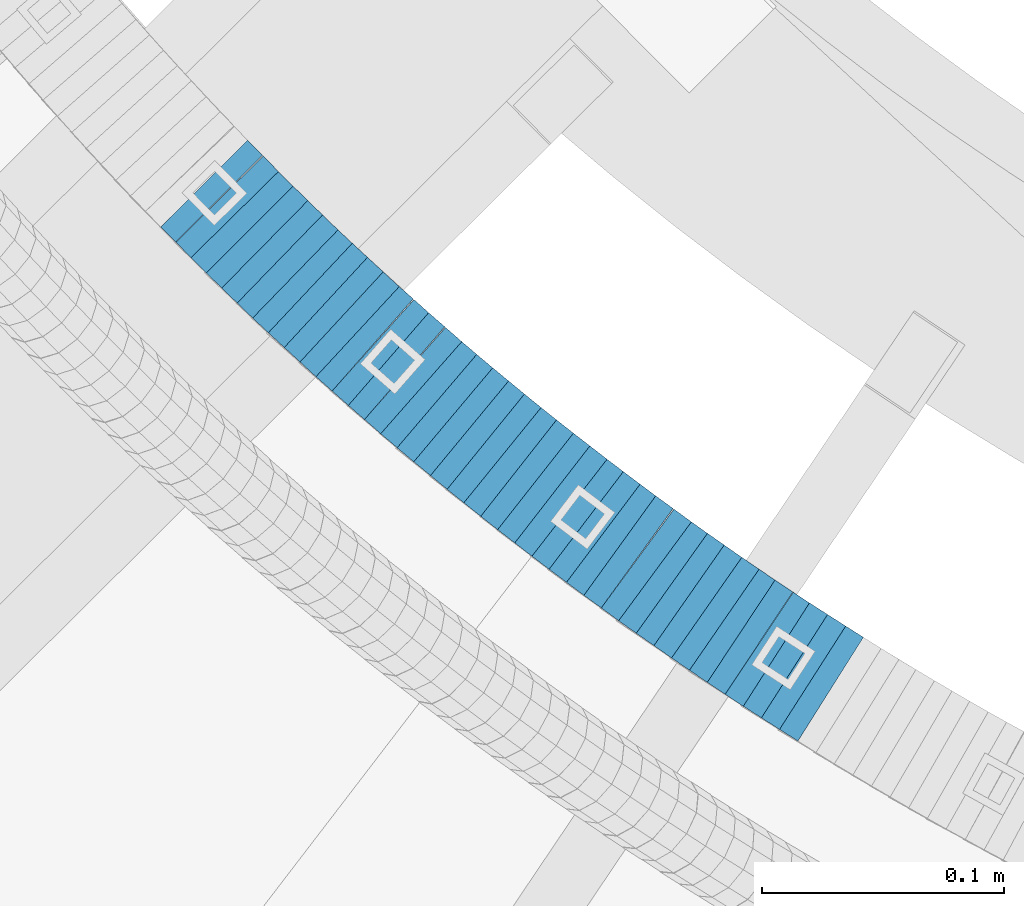
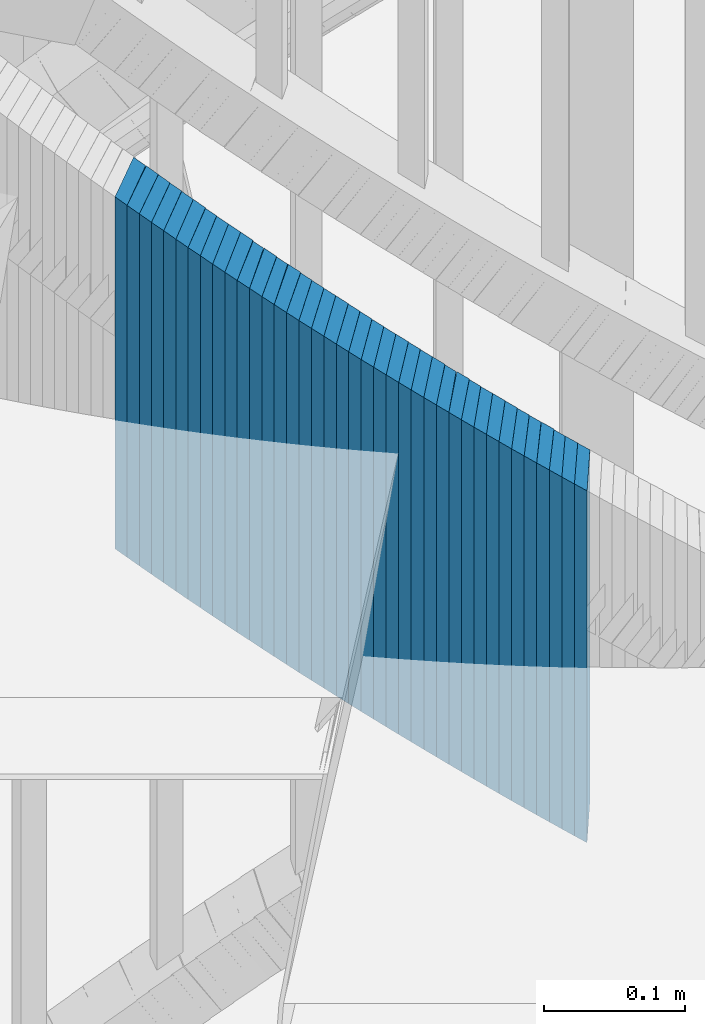
# One storey, part 887 of 975: 38 plates.
"""IFC2X3 building model written with IfcOpenShell, lengths in millimetres."""

from ifc_helpers import new_model, si_unit, frame, origin_with_axes, place, context, subcontext, project, spatial, faceted_brep, material, type_object, element, save


model = new_model("IFC2X3")

# Units and contexts
model_context = context("Model", 3, precision=1e-05, world=origin_with_axes())
body_context = subcontext(model_context, "Body", "Model", "MODEL_VIEW")
ifc_project = project(units=[si_unit("LENGTHUNIT", "METRE", prefix="MILLI"), si_unit("AREAUNIT", "SQUARE_METRE"), si_unit("VOLUMEUNIT", "CUBIC_METRE"), si_unit("MASSUNIT", "GRAM", prefix="KILO"), si_unit("TIMEUNIT", "SECOND"), si_unit("PLANEANGLEUNIT", "RADIAN"), si_unit("SOLIDANGLEUNIT", "STERADIAN"), si_unit("THERMODYNAMICTEMPERATUREUNIT", "DEGREE_CELSIUS"), si_unit("LUMINOUSINTENSITYUNIT", "LUMEN")], contexts=[model_context])

# Site, building, storey
site_placement = place(None, origin_with_axes())
site = spatial("IfcSite", under=ifc_project, at=site_placement, CompositionType="ELEMENT")
building_placement = place(site_placement, origin_with_axes())
building = spatial("IfcBuilding", under=site, at=building_placement, Name="Undefined", CompositionType="ELEMENT")
storey_placement = place(building_placement, origin_with_axes())
storey = spatial("IfcBuildingStorey", under=building, at=storey_placement, Name="Undefined", CompositionType="ELEMENT", Elevation=0.0)

# Plates
ifc_material = material(Name="STEEL/A36")
plate_type = type_object("IfcPlateType", PredefinedType="NOTDEFINED")
plate_1_placement = place(storey_placement, frame((33739.9257432676, 2422.43444188556, 3793.22500005032), z_axis=(-0.707106781186601, 0.707106781186494, 2.36468622460961e-14), x_axis=(0.0, 0.0, 1.0)))
element("IfcPlate", 1, at=plate_1_placement, inside=storey, type_object=plate_type, material=ifc_material, Name="WALL", context=body_context, shape_type="Brep", body=[
    faceted_brep([(0.0, -25.3999999999724, -1.81898940354586e-11), (5.80000019073486, -25.3999999999796, 8.91403388975959), (5.80000019073486, 25.3999999999432, 8.91403388980689), (0.0, 25.3999999999869, 1.45519152283669e-11), (310.600006103515, -25.3999999999796, 8.91403388975959), (310.600006103515, 25.3999999999432, 8.91403388980689), (304.799987792969, -25.3999999999724, -1.81898940354586e-11), (304.799987792969, 25.3999999999869, 1.45519152283669e-11)], [[[0, 1, 2, 3]], [[1, 4, 5, 2]], [[4, 6, 7, 5]], [[6, 0, 3, 7]], [[5, 7, 3, 2]], [[6, 4, 1, 0]]]),
])
plate_2_placement = place(storey_placement, frame((33746.3666034738, 2415.89246817069, 3787.52500005032), z_axis=(-0.701517264855551, 0.712652458853252, 0.0), x_axis=(0.0, 0.0, 1.0)))
element("IfcPlate", 2, at=plate_2_placement, inside=storey, type_object=plate_type, material=ifc_material, Name="WALL", context=body_context, shape_type="Brep", body=[
    faceted_brep([(0.0, -25.3999999999724, -1.81898940354586e-11), (5.69999980926514, -25.3999999999542, 8.98276138300935), (5.69999980926514, 25.3999999999614, 8.98276138309302), (0.0, 25.3999999999869, 1.45519152283669e-11), (310.5, -25.3999999999542, 8.98276138300935), (310.5, 25.3999999999614, 8.98276138309302), (304.799987792969, -25.3999999999724, -1.81898940354586e-11), (304.799987792969, 25.3999999999869, 1.45519152283669e-11)], [[[0, 1, 2, 3]], [[1, 4, 5, 2]], [[4, 6, 7, 5]], [[6, 0, 3, 7]], [[5, 7, 3, 2]], [[6, 4, 1, 0]]]),
])
plate_3_placement = place(storey_placement, frame((33752.5257432694, 2409.73444188556, 3781.82500005032), z_axis=(-0.707106781186601, 0.707106781186494, 2.36468622460961e-14), x_axis=(0.0, 0.0, 1.0)))
element("IfcPlate", 3, at=plate_3_placement, inside=storey, type_object=plate_type, material=ifc_material, Name="WALL", context=body_context, shape_type="Brep", body=[
    faceted_brep([(0.0, -25.3999999999724, -1.81898940354586e-11), (5.69999980926514, -25.4000000000269, 8.91066741947361), (5.69999980926514, 25.4000000000269, 8.91066741941904), (0.0, 25.3999999999869, 1.45519152283669e-11), (310.5, -25.4000000000269, 8.91066741947361), (310.5, 25.4000000000269, 8.91066741941904), (304.799987792969, -25.3999999999724, -1.81898940354586e-11), (304.799987792969, 25.3999999999869, 1.45519152283669e-11)], [[[0, 1, 2, 3]], [[1, 4, 5, 2]], [[4, 6, 7, 5]], [[6, 0, 3, 7]], [[5, 7, 3, 2]], [[6, 4, 1, 0]]]),
])
plate_4_placement = place(storey_placement, frame((33758.7837695498, 2403.57530209825, 3776.12500005032), z_axis=(-0.712652459353194, 0.701517264347674, 0.0), x_axis=(0.0, 0.0, 1.0)))
element("IfcPlate", 4, at=plate_4_placement, inside=storey, type_object=plate_type, material=ifc_material, Name="WALL", context=body_context, shape_type="Brep", body=[
    faceted_brep([(0.0, -25.3999999999724, -1.81898940354586e-11), (5.69999980926514, -25.3999999999542, 8.98276138300935), (5.69999980926514, 25.3999999999614, 8.98276138309302), (0.0, 25.3999999999869, 1.45519152283669e-11), (310.5, -25.3999999999542, 8.98276138300935), (310.5, 25.3999999999614, 8.98276138309302), (304.799987792969, -25.3999999999724, -1.81898940354586e-11), (304.799987792969, 25.3999999999869, 1.45519152283669e-11)], [[[0, 1, 2, 3]], [[1, 4, 5, 2]], [[4, 6, 7, 5]], [[6, 0, 3, 7]], [[5, 7, 3, 2]], [[6, 4, 1, 0]]]),
])
plate_5_placement = place(storey_placement, frame((33765.038429499, 2397.51723130203, 3770.32500005032), z_axis=(-0.718240222804791, 0.695795215810891, 0.0), x_axis=(0.0, 0.0, 1.0)))
element("IfcPlate", 5, at=plate_5_placement, inside=storey, type_object=plate_type, material=ifc_material, Name="WALL", context=body_context, shape_type="Brep", body=[
    faceted_brep([(0.0, -25.3999999999724, -1.81898940354586e-11), (5.80000019073486, -25.3999999999796, 8.91403388975959), (5.80000019073486, 25.3999999999432, 8.91403388980689), (0.0, 25.3999999999869, 1.45519152283669e-11), (310.600006103515, -25.3999999999796, 8.91403388975959), (310.600006103515, 25.3999999999432, 8.91403388980689), (304.799987792969, -25.3999999999724, -1.81898940354586e-11), (304.799987792969, 25.3999999999869, 1.45519152283669e-11)], [[[0, 1, 2, 3]], [[1, 4, 5, 2]], [[4, 6, 7, 5]], [[6, 0, 3, 7]], [[5, 7, 3, 2]], [[6, 4, 1, 0]]]),
])
for number, where, z_axis, x_axis, name in (
    (6, (33771.4384294939, 2391.31723130137, 3764.62500005032), (-0.718240222804791, 0.695795215810891, 0.0), (0.0, 0.0, 1.0), "WALL"),
    (7, (33777.6468117863, 2385.4952862224, 3758.92500005032), (-0.729187266944916, 0.684314203948306, 0.0), (0.0, 0.0, 1.0), "WALL"),
):
    element("IfcPlate", number, at=place(storey_placement, frame(where, z_axis=z_axis, x_axis=x_axis)), inside=storey, type_object=plate_type, material=ifc_material, Name=name, context=body_context, shape_type="Brep", body=[
        faceted_brep([(0.0, -25.3999999999724, -1.81898940354586e-11), (5.69999980926514, -25.4000000000269, 8.91066741947361), (5.69999980926514, 25.4000000000269, 8.91066741941904), (0.0, 25.3999999999869, 1.45519152283669e-11), (310.5, -25.4000000000269, 8.91066741947361), (310.5, 25.4000000000269, 8.91066741941904), (304.799987792969, -25.3999999999724, -1.81898940354586e-11), (304.799987792969, 25.3999999999869, 1.45519152283669e-11)], [[[0, 1, 2, 3]], [[1, 4, 5, 2]], [[4, 6, 7, 5]], [[6, 0, 3, 7]], [[5, 7, 3, 2]], [[6, 4, 1, 0]]]),
    ])
plate_6_placement = place(storey_placement, frame((33784.1052805755, 2379.52709802723, 3753.12500005032), z_axis=(-0.734376708079798, 0.678742109073748, 0.0), x_axis=(0.0, 0.0, 1.0)))
element("IfcPlate", 8, at=plate_6_placement, inside=storey, type_object=plate_type, material=ifc_material, Name="WALL", context=body_context, shape_type="Brep", body=[
    faceted_brep([(0.0, -25.3999999999724, -1.81898940354586e-11), (5.80000019073486, -25.4000000000815, 8.99388694768095), (5.80000019073486, 25.4000000000342, 8.99388694761365), (0.0, 25.3999999999869, 1.45519152283669e-11), (310.600006103516, -25.4000000000815, 8.99388694768095), (310.600006103516, 25.4000000000342, 8.99388694761365), (304.799987792969, -25.3999999999724, -1.81898940354586e-11), (304.799987792969, 25.3999999999869, 1.45519152283669e-11)], [[[0, 1, 2, 3]], [[1, 4, 5, 2]], [[4, 6, 7, 5]], [[6, 0, 3, 7]], [[5, 7, 3, 2]], [[6, 4, 1, 0]]]),
])
plate_7_placement = place(storey_placement, frame((33790.5935456119, 2373.53793713606, 3747.42500005032), z_axis=(-0.734803444665826, 0.678280102691532, 0.0), x_axis=(0.0, 0.0, 1.0)))
element("IfcPlate", 9, at=plate_7_placement, inside=storey, type_object=plate_type, material=ifc_material, Name="WALL", context=body_context, shape_type="Brep", body=[
    faceted_brep([(0.0, -25.3999999999724, -1.81898940354586e-11), (5.69999980926514, -25.4000000000015, 8.84816360473997), (5.69999980926514, 25.4000000000487, 8.8481636046854), (0.0, 25.3999999999869, 1.45519152283669e-11), (310.5, -25.4000000000015, 8.84816360473997), (310.5, 25.4000000000487, 8.8481636046854), (304.799987792969, -25.3999999999724, -1.81898940354586e-11), (304.799987792969, 25.3999999999869, 1.45519152283669e-11)], [[[0, 1, 2, 3]], [[1, 4, 5, 2]], [[4, 6, 7, 5]], [[6, 0, 3, 7]], [[5, 7, 3, 2]], [[6, 4, 1, 0]]]),
])
plate_8_placement = place(storey_placement, frame((33797.2052805682, 2367.42709802726, 3741.72500005032), z_axis=(-0.734376708079798, 0.678742109073748, 0.0), x_axis=(0.0, 0.0, 1.0)))
element("IfcPlate", 10, at=plate_8_placement, inside=storey, type_object=plate_type, material=ifc_material, Name="WALL", context=body_context, shape_type="Brep", body=[
    faceted_brep([(0.0, -25.3999999999724, -1.81898940354586e-11), (5.69999980926514, -25.4000000000196, 8.98721313477654), (5.69999980926514, 25.4000000000669, 8.98721313470742), (0.0, 25.3999999999869, 1.45519152283669e-11), (310.5, -25.4000000000196, 8.98721313477654), (310.5, 25.4000000000669, 8.98721313470742), (304.799987792969, -25.3999999999724, -1.81898940354586e-11), (304.799987792969, 25.3999999999869, 1.45519152283669e-11)], [[[0, 1, 2, 3]], [[1, 4, 5, 2]], [[4, 6, 7, 5]], [[6, 0, 3, 7]], [[5, 7, 3, 2]], [[6, 4, 1, 0]]]),
])
plate_9_placement = place(storey_placement, frame((33803.4515923435, 2361.93640777576, 3736.02500005032), z_axis=(-0.750491265131667, 0.660880368115947, 0.0), x_axis=(0.0, 0.0, 1.0)))
element("IfcPlate", 11, at=plate_9_placement, inside=storey, type_object=plate_type, material=ifc_material, Name="WALL", context=body_context, shape_type="Brep", body=[
    faceted_brep([(0.0, -25.3999999999724, -1.81898940354586e-11), (5.69999980926514, -25.3999999999542, 8.93084526058738), (5.69999980926514, 25.3999999999178, 8.93084526067832), (0.0, 25.3999999999869, 1.45519152283669e-11), (310.5, -25.3999999999542, 8.93084526058738), (310.5, 25.3999999999178, 8.93084526067832), (304.799987792969, -25.3999999999724, -1.81898940354586e-11), (304.799987792969, 25.3999999999869, 1.45519152283669e-11)], [[[0, 1, 2, 3]], [[1, 4, 5, 2]], [[4, 6, 7, 5]], [[6, 0, 3, 7]], [[5, 7, 3, 2]], [[6, 4, 1, 0]]]),
])
plate_10_placement = place(storey_placement, frame((33810.3100739944, 2355.79567099413, 3730.22500005032), z_axis=(-0.744950446985006, 0.667119802986569, 0.0), x_axis=(0.0, 0.0, 1.0)))
element("IfcPlate", 12, at=plate_10_placement, inside=storey, type_object=plate_type, material=ifc_material, Name="WALL", context=body_context, shape_type="Brep", body=[
    faceted_brep([(0.0, -25.3999999999724, -1.81898940354586e-11), (5.80000019073486, -25.4000000000815, 8.99388694768095), (5.80000019073486, 25.4000000000342, 8.99388694761365), (0.0, 25.3999999999869, 1.45519152283669e-11), (310.600006103516, -25.4000000000815, 8.99388694768095), (310.600006103516, 25.4000000000342, 8.99388694761365), (304.799987792969, -25.3999999999724, -1.81898940354586e-11), (304.799987792969, 25.3999999999869, 1.45519152283669e-11)], [[[0, 1, 2, 3]], [[1, 4, 5, 2]], [[4, 6, 7, 5]], [[6, 0, 3, 7]], [[5, 7, 3, 2]], [[6, 4, 1, 0]]]),
])
plate_11_placement = place(storey_placement, frame((33816.6895518173, 2350.27788645097, 3724.52500005032), z_axis=(-0.756061291757536, 0.65450081979011, 0.0), x_axis=(0.0, 0.0, 1.0)))
element("IfcPlate", 13, at=plate_11_placement, inside=storey, type_object=plate_type, material=ifc_material, Name="WALL", context=body_context, shape_type="Brep", body=[
    faceted_brep([(0.0, -25.3999999999724, -1.81898940354586e-11), (5.69999980926514, -25.4000000000378, 8.86171531681612), (5.69999980926514, 25.3999999999978, 8.86171531676882), (0.0, 25.3999999999869, 1.45519152283669e-11), (310.5, -25.4000000000378, 8.86171531681612), (310.5, 25.3999999999978, 8.86171531676882), (304.799987792969, -25.3999999999724, -1.81898940354586e-11), (304.799987792969, 25.3999999999869, 1.45519152283669e-11)], [[[0, 1, 2, 3]], [[1, 4, 5, 2]], [[4, 6, 7, 5]], [[6, 0, 3, 7]], [[5, 7, 3, 2]], [[6, 4, 1, 0]]]),
])
plate_12_placement = place(storey_placement, frame((33823.5515923404, 2344.23640777523, 3718.82500005032), z_axis=(-0.750491265131667, 0.660880368115947, 0.0), x_axis=(0.0, 0.0, 1.0)))
element("IfcPlate", 14, at=plate_12_placement, inside=storey, type_object=plate_type, material=ifc_material, Name="WALL", context=body_context, shape_type="Brep", body=[
    faceted_brep([(0.0, -25.3999999999724, -1.81898940354586e-11), (5.69999980926514, -25.3999999999542, 8.93084526058738), (5.69999980926514, 25.3999999999178, 8.93084526067832), (0.0, 25.3999999999869, 1.45519152283669e-11), (310.5, -25.3999999999542, 8.93084526058738), (310.5, 25.3999999999178, 8.93084526067832), (304.799987792969, -25.3999999999724, -1.81898940354586e-11), (304.799987792969, 25.3999999999869, 1.45519152283669e-11)], [[[0, 1, 2, 3]], [[1, 4, 5, 2]], [[4, 6, 7, 5]], [[6, 0, 3, 7]], [[5, 7, 3, 2]], [[6, 4, 1, 0]]]),
])
plate_13_placement = place(storey_placement, frame((33830.0484747787, 2338.69911202166, 3713.02500005032), z_axis=(-0.760833952017173, 0.648946606014648, 0.0), x_axis=(0.0, 0.0, 1.0)))
element("IfcPlate", 15, at=plate_13_placement, inside=storey, type_object=plate_type, material=ifc_material, Name="WALL", context=body_context, shape_type="Brep", body=[
    faceted_brep([(0.0, -25.3999999999724, -1.81898940354586e-11), (5.80000019073486, -25.4000000000087, 8.9375610351708), (5.80000019073486, 25.400000000016, 8.93756103512715), (0.0, 25.3999999999869, 1.45519152283669e-11), (310.600006103516, -25.4000000000087, 8.9375610351708), (310.600006103516, 25.400000000016, 8.93756103512715), (304.799987792969, -25.3999999999724, -1.81898940354586e-11), (304.799987792969, 25.3999999999869, 1.45519152283669e-11)], [[[0, 1, 2, 3]], [[1, 4, 5, 2]], [[4, 6, 7, 5]], [[6, 0, 3, 7]], [[5, 7, 3, 2]], [[6, 4, 1, 0]]]),
])
plate_14_placement = place(storey_placement, frame((33836.8089175745, 2333.0172809163, 3707.32500005032), z_axis=(-0.765486270690877, 0.643452227740159, 0.0), x_axis=(0.0, 0.0, 1.0)))
element("IfcPlate", 16, at=plate_14_placement, inside=storey, type_object=plate_type, material=ifc_material, Name="WALL", context=body_context, shape_type="Brep", body=[
    faceted_brep([(0.0, -25.3999999999724, -1.81898940354586e-11), (5.69999980926514, -25.4000000000233, 9.01387786867781), (5.69999980926514, 25.400000000016, 9.01387786863415), (0.0, 25.3999999999869, 1.45519152283669e-11), (310.5, -25.4000000000233, 9.01387786867781), (310.5, 25.400000000016, 9.01387786863415), (304.799987792969, -25.3999999999724, -1.81898940354586e-11), (304.799987792969, 25.3999999999869, 1.45519152283669e-11)], [[[0, 1, 2, 3]], [[1, 4, 5, 2]], [[4, 6, 7, 5]], [[6, 0, 3, 7]], [[5, 7, 3, 2]], [[6, 4, 1, 0]]]),
])
plate_15_placement = place(storey_placement, frame((33843.5420197336, 2327.45635813541, 3701.62500005032), z_axis=(-0.770961751776529, 0.636881446815391, 0.0), x_axis=(0.0, 0.0, 1.0)))
element("IfcPlate", 17, at=plate_15_placement, inside=storey, type_object=plate_type, material=ifc_material, Name="WALL", context=body_context, shape_type="Brep", body=[
    faceted_brep([(0.0, -25.3999999999724, -1.81898940354586e-11), (5.69999980926514, -25.3999999999869, 8.94930171964734), (5.69999980926514, 25.4000000000051, 8.94930171966917), (0.0, 25.3999999999869, 1.45519152283669e-11), (310.5, -25.3999999999869, 8.94930171964734), (310.5, 25.4000000000051, 8.94930171966917), (304.799987792969, -25.3999999999724, -1.81898940354586e-11), (304.799987792969, 25.3999999999869, 1.45519152283669e-11)], [[[0, 1, 2, 3]], [[1, 4, 5, 2]], [[4, 6, 7, 5]], [[6, 0, 3, 7]], [[5, 7, 3, 2]], [[6, 4, 1, 0]]]),
])
plate_16_placement = place(storey_placement, frame((33850.4420197282, 2321.75635813531, 3695.82500005032), z_axis=(-0.770961751776529, 0.636881446815391, 0.0), x_axis=(0.0, 0.0, 1.0)))
element("IfcPlate", 18, at=plate_16_placement, inside=storey, type_object=plate_type, material=ifc_material, Name="WALL", context=body_context, shape_type="Brep", body=[
    faceted_brep([(0.0, -25.3999999999724, -1.81898940354586e-11), (5.80000019073486, -25.3999999999942, 8.94930171964734), (5.80000019073486, 25.4000000000015, 8.94930171966917), (0.0, 25.3999999999869, 1.45519152283669e-11), (310.600006103516, -25.3999999999942, 8.94930171964734), (310.600006103516, 25.4000000000015, 8.94930171966917), (304.799987792969, -25.3999999999724, -1.81898940354586e-11), (304.799987792969, 25.3999999999869, 1.45519152283669e-11)], [[[0, 1, 2, 3]], [[1, 4, 5, 2]], [[4, 6, 7, 5]], [[6, 0, 3, 7]], [[5, 7, 3, 2]], [[6, 4, 1, 0]]]),
])
plate_17_placement = place(storey_placement, frame((33857.1715207387, 2316.29596523588, 3690.12500005032), z_axis=(-0.776458094333385, 0.630168888270572, 0.0), x_axis=(0.0, 0.0, 1.0)))
element("IfcPlate", 19, at=plate_17_placement, inside=storey, type_object=plate_type, material=ifc_material, Name="WALL", context=body_context, shape_type="Brep", body=[
    faceted_brep([(0.0, -25.3999999999724, -1.81898940354586e-11), (5.69999980926514, -25.4000000000196, 8.88650703432359), (5.69999980926514, 25.3999999999614, 8.88650703433086), (0.0, 25.3999999999869, 1.45519152283669e-11), (310.5, -25.4000000000196, 8.88650703432359), (310.5, 25.3999999999614, 8.88650703433086), (304.799987792969, -25.3999999999724, -1.81898940354586e-11), (304.799987792969, 25.3999999999869, 1.45519152283669e-11)], [[[0, 1, 2, 3]], [[1, 4, 5, 2]], [[4, 6, 7, 5]], [[6, 0, 3, 7]], [[5, 7, 3, 2]], [[6, 4, 1, 0]]]),
])
plate_18_placement = place(storey_placement, frame((33864.0324851955, 2310.80799738925, 3684.32500005032), z_axis=(-0.780868809052787, 0.624695048042229, 0.0), x_axis=(0.0, 0.0, 1.0)))
element("IfcPlate", 20, at=plate_18_placement, inside=storey, type_object=plate_type, material=ifc_material, Name="WALL", context=body_context, shape_type="Brep", body=[
    faceted_brep([(0.0, -25.3999999999724, -1.81898940354586e-11), (5.80000019073486, -25.3999999999105, 8.96270084375283), (5.80000019073486, 25.399999999936, 8.96270084385833), (0.0, 25.3999999999869, 1.45519152283669e-11), (310.600006103516, -25.3999999999105, 8.96270084375283), (310.600006103516, 25.399999999936, 8.96270084385833), (304.799987792969, -25.3999999999724, -1.81898940354586e-11), (304.799987792969, 25.3999999999869, 1.45519152283669e-11)], [[[0, 1, 2, 3]], [[1, 4, 5, 2]], [[4, 6, 7, 5]], [[6, 0, 3, 7]], [[5, 7, 3, 2]], [[6, 4, 1, 0]]]),
])
plate_19_placement = place(storey_placement, frame((33870.8578983894, 2305.44641544667, 3678.62500005032), z_axis=(-0.786318338857121, 0.617821551887742, 0.0), x_axis=(0.0, 0.0, 1.0)))
element("IfcPlate", 21, at=plate_19_placement, inside=storey, type_object=plate_type, material=ifc_material, Name="WALL", context=body_context, shape_type="Brep", body=[
    faceted_brep([(0.0, -25.3999999999724, -1.81898940354586e-11), (5.69999980926514, -25.3999999999469, 8.90224647518698), (5.69999980926514, 25.399999999936, 8.90224647526338), (0.0, 25.3999999999869, 1.45519152283669e-11), (310.5, -25.3999999999469, 8.90224647518698), (310.5, 25.399999999936, 8.90224647526338), (304.799987792969, -25.3999999999724, -1.81898940354586e-11), (304.799987792969, 25.3999999999869, 1.45519152283669e-11)], [[[0, 1, 2, 3]], [[1, 4, 5, 2]], [[4, 6, 7, 5]], [[6, 0, 3, 7]], [[5, 7, 3, 2]], [[6, 4, 1, 0]]]),
])
plate_20_placement = place(storey_placement, frame((33877.8201336173, 2300.05389486821, 3672.82500005032), z_axis=(-0.79054981213442, 0.612397742104127, 0.0), x_axis=(0.0, 0.0, 1.0)))
element("IfcPlate", 22, at=plate_20_placement, inside=storey, type_object=plate_type, material=ifc_material, Name="WALL", context=body_context, shape_type="Brep", body=[
    faceted_brep([(0.0, -25.3999999999724, -1.81898940354586e-11), (5.80000019073486, -25.3999999999432, 8.98109149925949), (5.80000019073486, 25.3999999999651, 8.98109149937954), (0.0, 25.3999999999869, 1.45519152283669e-11), (310.600006103516, -25.3999999999432, 8.98109149925949), (310.600006103516, 25.3999999999651, 8.98109149937954), (304.799987792969, -25.3999999999724, -1.81898940354586e-11), (304.799987792969, 25.3999999999869, 1.45519152283669e-11)], [[[0, 1, 2, 3]], [[1, 4, 5, 2]], [[4, 6, 7, 5]], [[6, 0, 3, 7]], [[5, 7, 3, 2]], [[6, 4, 1, 0]]]),
])
plate_21_placement = place(storey_placement, frame((33884.9201336137, 2294.55389486847, 3667.12500005032), z_axis=(-0.79054981213442, 0.612397742104127, 0.0), x_axis=(0.0, 0.0, 1.0)))
element("IfcPlate", 23, at=plate_21_placement, inside=storey, type_object=plate_type, material=ifc_material, Name="WALL", context=body_context, shape_type="Brep", body=[
    faceted_brep([(0.0, -25.3999999999724, -1.81898940354586e-11), (5.69999980926514, -25.3999999999542, 8.98276138300935), (5.69999980926514, 25.3999999999614, 8.98276138309302), (0.0, 25.3999999999869, 1.45519152283669e-11), (310.5, -25.3999999999542, 8.98276138300935), (310.5, 25.3999999999614, 8.98276138309302), (304.799987792969, -25.3999999999724, -1.81898940354586e-11), (304.799987792969, 25.3999999999869, 1.45519152283669e-11)], [[[0, 1, 2, 3]], [[1, 4, 5, 2]], [[4, 6, 7, 5]], [[6, 0, 3, 7]], [[5, 7, 3, 2]], [[6, 4, 1, 0]]]),
])
plate_22_placement = place(storey_placement, frame((33891.8415647351, 2289.29096106949, 3661.42500005032), z_axis=(-0.795946119280133, 0.605367471213061, 0.0), x_axis=(0.0, 0.0, 1.0)))
element("IfcPlate", 24, at=plate_22_placement, inside=storey, type_object=plate_type, material=ifc_material, Name="WALL", context=body_context, shape_type="Brep", body=[
    faceted_brep([(0.0, -25.3999999999724, -1.81898940354586e-11), (5.69999980926514, -25.4000000000269, 8.9196414947728), (5.69999980926514, 25.3999999999796, 8.91964149476189), (0.0, 25.3999999999869, 1.45519152283669e-11), (310.5, -25.4000000000269, 8.9196414947728), (310.5, 25.3999999999796, 8.91964149476189), (304.799987792969, -25.3999999999724, -1.81898940354586e-11), (304.799987792969, 25.3999999999869, 1.45519152283669e-11)], [[[0, 1, 2, 3]], [[1, 4, 5, 2]], [[4, 6, 7, 5]], [[6, 0, 3, 7]], [[5, 7, 3, 2]], [[6, 4, 1, 0]]]),
])
plate_23_placement = place(storey_placement, frame((33898.9052309662, 2283.99392963938, 3655.62500005032), z_axis=(-0.8, 0.6, 0.0), x_axis=(0.0, 0.0, 1.0)))
element("IfcPlate", 25, at=plate_23_placement, inside=storey, type_object=plate_type, material=ifc_material, Name="WALL", context=body_context, shape_type="Brep", body=[
    faceted_brep([(0.0, -25.3999999999724, -1.81898940354586e-11), (5.80000019073486, -25.3999999999978, 9.00055599211555), (5.80000019073486, 25.3999999999651, 9.00055599218103), (0.0, 25.3999999999869, 1.45519152283669e-11), (310.600006103516, -25.3999999999978, 9.00055599211555), (310.600006103516, 25.3999999999651, 9.00055599218103), (304.799987792969, -25.3999999999724, -1.81898940354586e-11), (304.799987792969, 25.3999999999869, 1.45519152283669e-11)], [[[0, 1, 2, 3]], [[1, 4, 5, 2]], [[4, 6, 7, 5]], [[6, 0, 3, 7]], [[5, 7, 3, 2]], [[6, 4, 1, 0]]]),
])
plate_24_placement = place(storey_placement, frame((33906.1052309662, 2278.59392963895, 3649.92500005032), z_axis=(-0.8, 0.6, 0.0), x_axis=(0.0, 0.0, 1.0)))
element("IfcPlate", 26, at=plate_24_placement, inside=storey, type_object=plate_type, material=ifc_material, Name="WALL", context=body_context, shape_type="Brep", body=[
    faceted_brep([(0.0, -25.3999999999724, -1.81898940354586e-11), (5.69999980926514, -25.3999999999978, 9.00277709959482), (5.69999980926514, 25.3999999999651, 9.00277709966031), (0.0, 25.3999999999869, 1.45519152283669e-11), (310.5, -25.3999999999978, 9.00277709959482), (310.5, 25.3999999999651, 9.00277709966031), (304.799987792969, -25.3999999999724, -1.81898940354586e-11), (304.799987792969, 25.3999999999869, 1.45519152283669e-11)], [[[0, 1, 2, 3]], [[1, 4, 5, 2]], [[4, 6, 7, 5]], [[6, 0, 3, 7]], [[5, 7, 3, 2]], [[6, 4, 1, 0]]]),
])
plate_25_placement = place(storey_placement, frame((33912.9366910419, 2273.66518203456, 3644.12500005032), z_axis=(-0.810679228188928, 0.585490554136447, 0.0), x_axis=(0.0, 0.0, 1.0)))
element("IfcPlate", 27, at=plate_25_placement, inside=storey, type_object=plate_type, material=ifc_material, Name="WALL", context=body_context, shape_type="Brep", body=[
    faceted_brep([(0.0, -25.3999999999724, -1.81898940354586e-11), (5.80000019073486, -25.3999999999724, 8.87524604794817), (5.80000019073486, 25.3999999999651, 8.87524604802456), (0.0, 25.3999999999869, 1.45519152283669e-11), (310.600006103516, -25.3999999999724, 8.87524604794817), (310.600006103516, 25.3999999999651, 8.87524604802456), (304.799987792969, -25.3999999999724, -1.81898940354586e-11), (304.799987792969, 25.3999999999869, 1.45519152283669e-11)], [[[0, 1, 2, 3]], [[1, 4, 5, 2]], [[4, 6, 7, 5]], [[6, 0, 3, 7]], [[5, 7, 3, 2]], [[6, 4, 1, 0]]]),
])
plate_26_placement = place(storey_placement, frame((33920.3227936425, 2268.22948649496, 3638.42500005032), z_axis=(-0.805336884132331, 0.592817428097411, 0.0), x_axis=(0.0, 0.0, 1.0)))
element("IfcPlate", 28, at=plate_26_placement, inside=storey, type_object=plate_type, material=ifc_material, Name="WALL", context=body_context, shape_type="Brep", body=[
    faceted_brep([(0.0, -25.3999999999724, -1.81898940354586e-11), (5.69999980926514, -25.4000000000851, 8.94035816198448), (5.69999980926514, 25.4000000000524, 8.94035816188989), (0.0, 25.3999999999869, 1.45519152283669e-11), (310.5, -25.4000000000851, 8.94035816198448), (310.5, 25.4000000000524, 8.94035816188989), (304.799987792969, -25.3999999999724, -1.81898940354586e-11), (304.799987792969, 25.3999999999869, 1.45519152283669e-11)], [[[0, 1, 2, 3]], [[1, 4, 5, 2]], [[4, 6, 7, 5]], [[6, 0, 3, 7]], [[5, 7, 3, 2]], [[6, 4, 1, 0]]]),
])
plate_27_placement = place(storey_placement, frame((33927.3018608783, 2263.26189084614, 3632.62500005032), z_axis=(-0.814486661754882, 0.580182279825392, 0.0), x_axis=(0.0, 0.0, 1.0)))
element("IfcPlate", 29, at=plate_27_placement, inside=storey, type_object=plate_type, material=ifc_material, Name="WALL", context=body_context, shape_type="Brep", body=[
    faceted_brep([(0.0, -25.3999999999724, -1.81898940354586e-11), (5.80000019073486, -25.3999999999105, 8.96270084375283), (5.80000019073486, 25.399999999936, 8.96270084385833), (0.0, 25.3999999999869, 1.45519152283669e-11), (310.600006103516, -25.3999999999105, 8.96270084375283), (310.600006103516, 25.399999999936, 8.96270084385833), (304.799987792969, -25.3999999999724, -1.81898940354586e-11), (304.799987792969, 25.3999999999869, 1.45519152283669e-11)], [[[0, 1, 2, 3]], [[1, 4, 5, 2]], [[4, 6, 7, 5]], [[6, 0, 3, 7]], [[5, 7, 3, 2]], [[6, 4, 1, 0]]]),
])
for number, where, z_axis, x_axis, name in (
    (30, (33934.4120253145, 2258.29581173811, 3626.92500005032), (-0.819759137821163, 0.572708438875056, 0.0), (0.0, 0.0, 1.0), "WALL"),
    (31, (33941.712025311, 2253.19581173794, 3621.22500005032), (-0.819759137821163, 0.572708438875056, 0.0), (0.0, 0.0, 1.0), "WALL"),
):
    element("IfcPlate", number, at=place(storey_placement, frame(where, z_axis=z_axis, x_axis=x_axis)), inside=storey, type_object=plate_type, material=ifc_material, Name=name, context=body_context, shape_type="Brep", body=[
        faceted_brep([(0.0, -25.3999999999724, -1.81898940354586e-11), (5.69999980926514, -25.4000000000269, 8.91066741947361), (5.69999980926514, 25.4000000000269, 8.91066741941904), (0.0, 25.3999999999869, 1.45519152283669e-11), (310.5, -25.4000000000269, 8.91066741947361), (310.5, 25.4000000000269, 8.91066741941904), (304.799987792969, -25.3999999999724, -1.81898940354586e-11), (304.799987792969, 25.3999999999869, 1.45519152283669e-11)], [[[0, 1, 2, 3]], [[1, 4, 5, 2]], [[4, 6, 7, 5]], [[6, 0, 3, 7]], [[5, 7, 3, 2]], [[6, 4, 1, 0]]]),
    ])
plate_28_placement = place(storey_placement, frame((33948.9790428989, 2248.18808813134, 3615.42500005032), z_axis=(-0.823392066704671, 0.567472910796463, 0.0), x_axis=(0.0, 0.0, 1.0)))
element("IfcPlate", 32, at=plate_28_placement, inside=storey, type_object=plate_type, material=ifc_material, Name="WALL", context=body_context, shape_type="Brep", body=[
    faceted_brep([(0.0, -25.3999999999724, -1.81898940354586e-11), (5.80000019073486, -25.4000000000815, 8.99388694768095), (5.80000019073486, 25.4000000000342, 8.99388694761365), (0.0, 25.3999999999869, 1.45519152283669e-11), (310.600006103516, -25.4000000000815, 8.99388694768095), (310.600006103516, 25.4000000000342, 8.99388694761365), (304.799987792969, -25.3999999999724, -1.81898940354586e-11), (304.799987792969, 25.3999999999869, 1.45519152283669e-11)], [[[0, 1, 2, 3]], [[1, 4, 5, 2]], [[4, 6, 7, 5]], [[6, 0, 3, 7]], [[5, 7, 3, 2]], [[6, 4, 1, 0]]]),
])
plate_29_placement = place(storey_placement, frame((33956.1856092009, 2243.32008944768, 3609.72500005032), z_axis=(-0.828588968736746, 0.559857411210905, -1.04603259387659e-10), x_axis=(0.0, 0.0, 1.0)))
element("IfcPlate", 33, at=plate_29_placement, inside=storey, type_object=plate_type, material=ifc_material, Name="WALL", context=body_context, shape_type="Brep", body=[
    faceted_brep([(0.0, -25.3999999999724, -1.81898940354586e-11), (5.69999980926514, -25.3999999999542, 8.93084526058738), (5.69999980926514, 25.3999999999178, 8.93084526067832), (0.0, 25.3999999999869, 1.45519152283669e-11), (310.5, -25.3999999999542, 8.93084526058738), (310.5, 25.3999999999178, 8.93084526067832), (304.799987792969, -25.3999999999724, -1.81898940354586e-11), (304.799987792969, 25.3999999999869, 1.45519152283669e-11)], [[[0, 1, 2, 3]], [[1, 4, 5, 2]], [[4, 6, 7, 5]], [[6, 0, 3, 7]], [[5, 7, 3, 2]], [[6, 4, 1, 0]]]),
])
plate_30_placement = place(storey_placement, frame((33963.3885034742, 2238.55193303484, 3604.02500005032), z_axis=(-0.83377966131478, 0.552097343208434, 0.0), x_axis=(0.0, 0.0, 1.0)))
element("IfcPlate", 34, at=plate_30_placement, inside=storey, type_object=plate_type, material=ifc_material, Name="WALL", context=body_context, shape_type="Brep", body=[
    faceted_brep([(0.0, -25.3999999999724, -1.81898940354586e-11), (5.69999980926514, -25.4000000000306, 8.88144111634756), (5.69999980926514, 25.4000000000378, 8.88144111629663), (0.0, 25.3999999999869, 1.45519152283669e-11), (310.5, -25.4000000000306, 8.88144111634756), (310.5, 25.4000000000378, 8.88144111629663), (304.799987792969, -25.3999999999724, -1.81898940354586e-11), (304.799987792969, 25.3999999999869, 1.45519152283669e-11)], [[[0, 1, 2, 3]], [[1, 4, 5, 2]], [[4, 6, 7, 5]], [[6, 0, 3, 7]], [[5, 7, 3, 2]], [[6, 4, 1, 0]]]),
])
plate_31_placement = place(storey_placement, frame((33970.9546159382, 2233.50800711411, 3598.32500005032), z_axis=(-0.832050294337844, 0.554700196225229, 0.0), x_axis=(0.0, 0.0, 1.0)))
element("IfcPlate", 35, at=plate_31_placement, inside=storey, type_object=plate_type, material=ifc_material, Name="WALL", context=body_context, shape_type="Brep", body=[
    faceted_brep([(0.0, -25.3999999999724, -1.81898940354586e-11), (5.69999980926514, -25.4000000000233, 9.01387786867781), (5.69999980926514, 25.400000000016, 9.01387786863415), (0.0, 25.3999999999869, 1.45519152283669e-11), (310.5, -25.4000000000233, 9.01387786867781), (310.5, 25.400000000016, 9.01387786863415), (304.799987792969, -25.3999999999724, -1.81898940354586e-11), (304.799987792969, 25.3999999999869, 1.45519152283669e-11)], [[[0, 1, 2, 3]], [[1, 4, 5, 2]], [[4, 6, 7, 5]], [[6, 0, 3, 7]], [[5, 7, 3, 2]], [[6, 4, 1, 0]]]),
])
plate_32_placement = place(storey_placement, frame((33978.0571948301, 2228.96762322207, 3592.52500005032), z_axis=(-0.842271400952091, 0.539053695969337, 0.0), x_axis=(0.0, 0.0, 1.0)))
element("IfcPlate", 36, at=plate_32_placement, inside=storey, type_object=plate_type, material=ifc_material, Name="WALL", context=body_context, shape_type="Brep", body=[
    faceted_brep([(0.0, -25.3999999999724, -1.81898940354586e-11), (5.80000019073486, -25.3999999999687, 8.90449333185097), (5.80000019073486, 25.3999999999833, 8.90449333192373), (0.0, 25.3999999999869, 1.45519152283669e-11), (310.600006103516, -25.3999999999687, 8.90449333185097), (310.600006103516, 25.3999999999833, 8.90449333192373), (304.799987792969, -25.3999999999724, -1.81898940354586e-11), (304.799987792969, 25.3999999999869, 1.45519152283669e-11)], [[[0, 1, 2, 3]], [[1, 4, 5, 2]], [[4, 6, 7, 5]], [[6, 0, 3, 7]], [[5, 7, 3, 2]], [[6, 4, 1, 0]]]),
])
plate_33_placement = place(storey_placement, frame((33985.5571948284, 2224.167623222, 3586.82500005032), z_axis=(-0.842271400952091, 0.539053695969337, 0.0), x_axis=(0.0, 0.0, 1.0)))
element("IfcPlate", 37, at=plate_33_placement, inside=storey, type_object=plate_type, material=ifc_material, Name="WALL", context=body_context, shape_type="Brep", body=[
    faceted_brep([(0.0, -25.3999999999724, -1.81898940354586e-11), (5.69999980926514, -25.3999999999469, 8.90224647518698), (5.69999980926514, 25.399999999936, 8.90224647526338), (0.0, 25.3999999999869, 1.45519152283669e-11), (310.5, -25.3999999999469, 8.90224647518698), (310.5, 25.399999999936, 8.90224647526338), (304.799987792969, -25.3999999999724, -1.81898940354586e-11), (304.799987792969, 25.3999999999869, 1.45519152283669e-11)], [[[0, 1, 2, 3]], [[1, 4, 5, 2]], [[4, 6, 7, 5]], [[6, 0, 3, 7]], [[5, 7, 3, 2]], [[6, 4, 1, 0]]]),
])
plate_34_placement = place(storey_placement, frame((33993.0286529329, 2219.44934777954, 3581.12500005032), z_axis=(-0.845488903197307, 0.533992991124616, 0.0), x_axis=(0.0, 0.0, 1.0)))
element("IfcPlate", 38, at=plate_34_placement, inside=storey, type_object=plate_type, material=ifc_material, Name="WALL", context=body_context, shape_type="Brep", body=[
    faceted_brep([(0.0, -25.3999999999724, -1.81898940354586e-11), (5.69999980926514, -25.4000000000196, 8.98721313477654), (5.69999980926514, 25.4000000000669, 8.98721313470742), (0.0, 25.3999999999869, 1.45519152283669e-11), (310.5, -25.4000000000196, 8.98721313477654), (310.5, 25.4000000000669, 8.98721313470742), (304.799987792969, -25.3999999999724, -1.81898940354586e-11), (304.799987792969, 25.3999999999869, 1.45519152283669e-11)], [[[0, 1, 2, 3]], [[1, 4, 5, 2]], [[4, 6, 7, 5]], [[6, 0, 3, 7]], [[5, 7, 3, 2]], [[6, 4, 1, 0]]]),
])

save(model, "model.ifc")
